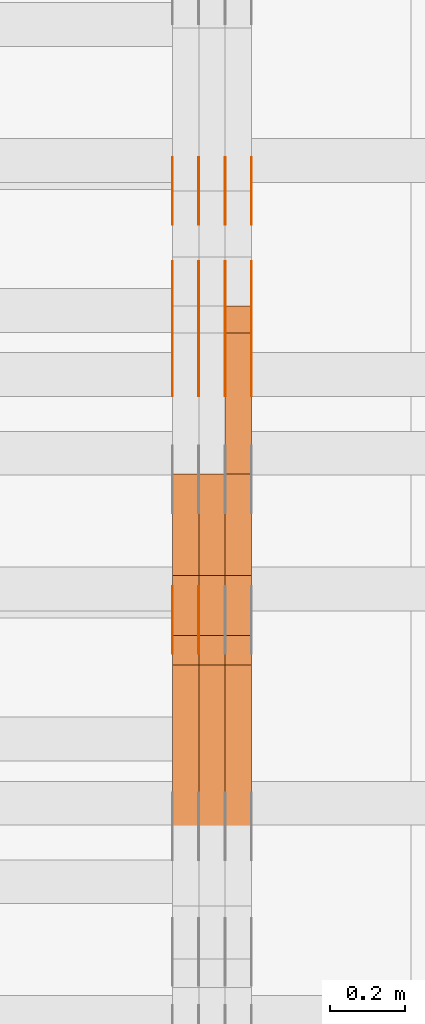
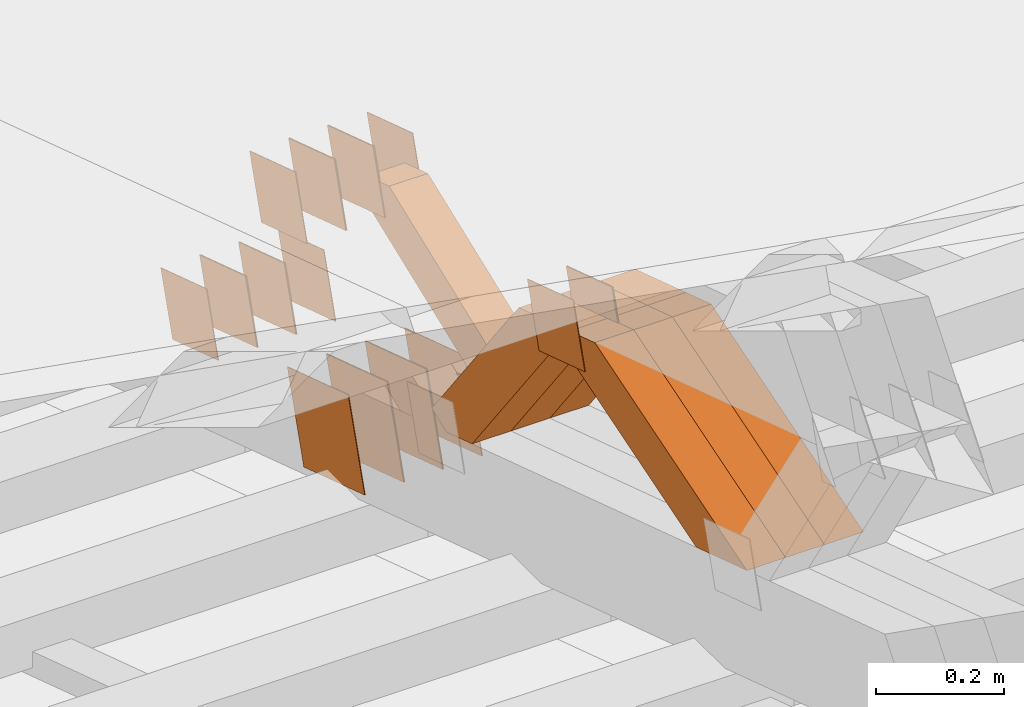
# One storey, part 176 of 385: 28 proxies.
"""IFC2X3 building model written with IfcOpenShell, lengths in millimetres."""

from ifc_helpers import new_model, entity, si_unit, converted_unit, derived_unit, direction, frame, origin, place, context, subcontext, project, spatial, polyline, outline, extrude, source, transform, mapped, material, type_object, type_shapes, element, save


model = new_model("IFC2X3")

# Units and contexts
model_context = context("Model", 3, precision=0.01, world=origin(), true_north=direction((6.12303176911189e-17, 1.0)))
body_context = subcontext(model_context, "Body", "Model", "MODEL_VIEW")
ifc_project = project(units=[si_unit("LENGTHUNIT", "METRE", prefix="MILLI"), si_unit("AREAUNIT", "SQUARE_METRE"), si_unit("VOLUMEUNIT", "CUBIC_METRE"), converted_unit("PLANEANGLEUNIT", "DEGREE", entity("IfcRatioMeasure", 0.0174532925199433), si_unit("PLANEANGLEUNIT", "RADIAN"), dimensions=[0, 0, 0, 0, 0, 0, 0]), si_unit("MASSUNIT", "GRAM", prefix="KILO"), derived_unit("MASSDENSITYUNIT", [(si_unit("MASSUNIT", "GRAM", prefix="KILO"), 1), (si_unit("LENGTHUNIT", "METRE"), -3)]), si_unit("TIMEUNIT", "SECOND"), si_unit("FREQUENCYUNIT", "HERTZ"), si_unit("THERMODYNAMICTEMPERATUREUNIT", "DEGREE_CELSIUS"), derived_unit("THERMALTRANSMITTANCEUNIT", [(si_unit("MASSUNIT", "GRAM", prefix="KILO"), 1), (si_unit("THERMODYNAMICTEMPERATUREUNIT", "KELVIN"), -1), (si_unit("TIMEUNIT", "SECOND"), -3)]), derived_unit("VOLUMETRICFLOWRATEUNIT", [(si_unit("LENGTHUNIT", "METRE"), 3), (si_unit("TIMEUNIT", "SECOND"), -1)]), si_unit("ELECTRICCURRENTUNIT", "AMPERE"), si_unit("ELECTRICVOLTAGEUNIT", "VOLT"), si_unit("POWERUNIT", "WATT"), si_unit("FORCEUNIT", "NEWTON", prefix="KILO"), si_unit("ILLUMINANCEUNIT", "LUX"), si_unit("LUMINOUSFLUXUNIT", "LUMEN"), si_unit("LUMINOUSINTENSITYUNIT", "CANDELA"), derived_unit("USERDEFINED", [(si_unit("MASSUNIT", "GRAM", prefix="KILO"), -1), (si_unit("LENGTHUNIT", "METRE"), -2), (si_unit("TIMEUNIT", "SECOND"), 3), (si_unit("LUMINOUSFLUXUNIT", "LUMEN"), 1)]), derived_unit("LINEARVELOCITYUNIT", [(si_unit("LENGTHUNIT", "METRE"), 1), (si_unit("TIMEUNIT", "SECOND"), -1)]), si_unit("PRESSUREUNIT", "PASCAL"), derived_unit("USERDEFINED", [(si_unit("LENGTHUNIT", "METRE"), -2), (si_unit("MASSUNIT", "GRAM", prefix="KILO"), 1), (si_unit("TIMEUNIT", "SECOND"), -2)])], contexts=[model_context])

# Site, building, storey
site_placement = place(None, origin())
site = spatial("IfcSite", under=ifc_project, at=site_placement, CompositionType="ELEMENT")
building_placement = place(site_placement, origin())
building = spatial("IfcBuilding", under=site, at=building_placement, CompositionType="ELEMENT")
storey_placement = place(building_placement, origin())
storey = spatial("IfcBuildingStorey", under=building, at=storey_placement, Name="Default", CompositionType="ELEMENT", Elevation=0.0)

# Proxies
ifc_material_1 = material(Name="IfcSurfaceStyle #68676")
building_element_proxy_type_1 = type_object("IfcBuildingElementProxyType", PredefinedType="NOTDEFINED", material=ifc_material_1)
shared_shape_1 = source(origin(), body_context, "Body", "SweptSolid", [
    extrude(outline(polyline([(-74.9998794200123, -59.999984515643), (74.9998565677174, -59.999984515643), (74.9998794200123, 59.999984515643), (-74.9998565677174, 59.999984515643), (-74.9998794200123, -59.999984515643)])), frame((75.0000769557496, 60.0000596852268, 0.0), z_axis=(0.0, 0.0, 1.0), x_axis=(-1.0, 0.0, 0.0)), (0.0, 0.0, 1.0), 1.3),
])
type_shapes(building_element_proxy_type_1, [shared_shape_1])
proxy_1_placement = place(building_placement, frame((3386.29999999999, 22649.3668870864, 1282.62115477841), z_axis=(-1.0, 0.0, 0.0), x_axis=(0.0, -0.951056516295124, 0.309016994375039)))
element("IfcBuildingElementProxy", 1, at=proxy_1_placement, inside=storey, type_object=building_element_proxy_type_1, material=ifc_material_1, context=body_context, shape_type="MappedRepresentation", body=[
    mapped(shared_shape_1, transform((0.0, 0.0, 0.0), scale=1.0)),
])
ifc_material_2 = material(Name="IfcSurfaceStyle #68619")
building_element_proxy_type_2 = type_object("IfcBuildingElementProxyType", PredefinedType="NOTDEFINED", material=ifc_material_2)
shared_shape_2 = source(origin(), body_context, "Body", "SweptSolid", [
    extrude(outline(polyline([(-74.9998794200123, -59.999984515643), (74.9998565677174, -59.999984515643), (74.9998794200123, 59.999984515643), (-74.9998565677174, 59.999984515643), (-74.9998794200123, -59.999984515643)])), frame((75.0000769557496, 60.0000596852268, 0.0), z_axis=(0.0, 0.0, 1.0), x_axis=(-1.0, 0.0, 0.0)), (0.0, 0.0, 1.0), 1.3),
])
type_shapes(building_element_proxy_type_2, [shared_shape_2])
proxy_2_placement = place(building_placement, frame((3315.0, 22649.3668870864, 1282.62115477841), z_axis=(-1.0, 0.0, 0.0), x_axis=(0.0, -0.951056516295124, 0.309016994375039)))
element("IfcBuildingElementProxy", 2, at=proxy_2_placement, inside=storey, type_object=building_element_proxy_type_2, material=ifc_material_2, context=body_context, shape_type="MappedRepresentation", body=[
    mapped(shared_shape_2, transform((0.0, 0.0, 0.0), scale=1.0)),
])
ifc_material_3 = material(Name="IfcSurfaceStyle #68562")
building_element_proxy_type_3 = type_object("IfcBuildingElementProxyType", PredefinedType="NOTDEFINED", material=ifc_material_3)
shared_shape_3 = source(origin(), body_context, "Body", "SweptSolid", [
    extrude(outline(polyline([(-74.9998794200123, -59.999984515643), (74.9998565677174, -59.999984515643), (74.9998794200123, 59.999984515643), (-74.9998565677174, 59.999984515643), (-74.9998794200123, -59.999984515643)])), frame((75.0000769557496, 60.0000596852268, 0.0), z_axis=(0.0, 0.0, 1.0), x_axis=(-1.0, 0.0, 0.0)), (0.0, 0.0, 1.0), 1.3),
])
type_shapes(building_element_proxy_type_3, [shared_shape_3])
proxy_3_placement = place(building_placement, frame((3316.29999999999, 22649.3668870864, 1282.62115477841), z_axis=(-1.0, 0.0, 0.0), x_axis=(0.0, -0.951056516295124, 0.309016994375039)))
element("IfcBuildingElementProxy", 3, at=proxy_3_placement, inside=storey, type_object=building_element_proxy_type_3, material=ifc_material_3, context=body_context, shape_type="MappedRepresentation", body=[
    mapped(shared_shape_3, transform((0.0, 0.0, 0.0), scale=1.0)),
])
ifc_material_4 = material(Name="IfcSurfaceStyle #68505")
building_element_proxy_type_4 = type_object("IfcBuildingElementProxyType", PredefinedType="NOTDEFINED", material=ifc_material_4)
shared_shape_4 = source(origin(), body_context, "Body", "SweptSolid", [
    extrude(outline(polyline([(-74.9998794200123, -59.999984515643), (74.9998565677174, -59.999984515643), (74.9998794200123, 59.999984515643), (-74.9998565677174, 59.999984515643), (-74.9998794200123, -59.999984515643)])), frame((75.0000769557496, 60.0000596852268, 0.0), z_axis=(0.0, 0.0, 1.0), x_axis=(-1.0, 0.0, 0.0)), (0.0, 0.0, 1.0), 1.29999999999999),
])
type_shapes(building_element_proxy_type_4, [shared_shape_4])
proxy_4_placement = place(building_placement, frame((3245.0, 22649.3668870864, 1282.62115477841), z_axis=(-1.0, 0.0, 0.0), x_axis=(0.0, -0.951056516295124, 0.309016994375039)))
element("IfcBuildingElementProxy", 4, at=proxy_4_placement, inside=storey, type_object=building_element_proxy_type_4, material=ifc_material_4, context=body_context, shape_type="MappedRepresentation", body=[
    mapped(shared_shape_4, transform((0.0, 0.0, 0.0), scale=1.0)),
])
ifc_material_5 = material(Name="IfcSurfaceStyle #68448")
building_element_proxy_type_5 = type_object("IfcBuildingElementProxyType", PredefinedType="NOTDEFINED", material=ifc_material_5)
shared_shape_5 = source(origin(), body_context, "Body", "SweptSolid", [
    extrude(outline(polyline([(-74.9998794200123, -59.999984515643), (74.9998565677174, -59.999984515643), (74.9998794200123, 59.999984515643), (-74.9998565677174, 59.999984515643), (-74.9998794200123, -59.999984515643)])), frame((75.0000769557496, 60.0000596852268, 0.0), z_axis=(0.0, 0.0, 1.0), x_axis=(-1.0, 0.0, 0.0)), (0.0, 0.0, 1.0), 1.29999999999999),
])
type_shapes(building_element_proxy_type_5, [shared_shape_5])
proxy_5_placement = place(building_placement, frame((3246.29999999999, 22649.3668870864, 1282.62115477841), z_axis=(-1.0, 0.0, 0.0), x_axis=(0.0, -0.951056516295124, 0.309016994375039)))
element("IfcBuildingElementProxy", 5, at=proxy_5_placement, inside=storey, type_object=building_element_proxy_type_5, material=ifc_material_5, context=body_context, shape_type="MappedRepresentation", body=[
    mapped(shared_shape_5, transform((0.0, 0.0, 0.0), scale=1.0)),
])
ifc_material_6 = material(Name="IfcSurfaceStyle #68391")
building_element_proxy_type_6 = type_object("IfcBuildingElementProxyType", PredefinedType="NOTDEFINED", material=ifc_material_6)
shared_shape_6 = source(origin(), body_context, "Body", "SweptSolid", [
    extrude(outline(polyline([(-74.9998794200123, -59.999984515643), (74.9998565677174, -59.999984515643), (74.9998794200123, 59.999984515643), (-74.9998565677174, 59.999984515643), (-74.9998794200123, -59.999984515643)])), frame((75.0000769557496, 60.0000596852268, 0.0), z_axis=(0.0, 0.0, 1.0), x_axis=(-1.0, 0.0, 0.0)), (0.0, 0.0, 1.0), 1.29999999999999),
])
type_shapes(building_element_proxy_type_6, [shared_shape_6])
proxy_6_placement = place(building_placement, frame((3175.0, 22649.3668870864, 1282.62115477841), z_axis=(-1.0, 0.0, 0.0), x_axis=(0.0, -0.951056516295124, 0.309016994375039)))
element("IfcBuildingElementProxy", 6, at=proxy_6_placement, inside=storey, type_object=building_element_proxy_type_6, material=ifc_material_6, context=body_context, shape_type="MappedRepresentation", body=[
    mapped(shared_shape_6, transform((0.0, 0.0, 0.0), scale=1.0)),
])
ifc_material_7 = material(Name="IfcSurfaceStyle #67992")
building_element_proxy_type_7 = type_object("IfcBuildingElementProxyType", PredefinedType="NOTDEFINED", material=ifc_material_7)
shared_shape_7 = source(origin(), body_context, "Body", "SweptSolid", [
    extrude(outline(polyline([(-99.9999579276585, -84.0000593595837), (100.000141865112, -84.0000593595837), (99.9999579276589, 84.0000593595837), (-100.000141865112, 84.0000593595837), (-99.9999579276585, -84.0000593595837)])), frame((100.000141865112, 84.0000593595837, 0.0), z_axis=(0.0, 0.0, 1.0), x_axis=(-1.0, 0.0, 0.0)), (0.0, 0.0, 1.0), 1.3),
])
type_shapes(building_element_proxy_type_7, [shared_shape_7])
proxy_7_placement = place(building_placement, frame((3386.29999999999, 22239.7296395088, 1287.96775368191), z_axis=(-1.0, 0.0, 0.0), x_axis=(0.0, -0.951056516295124, 0.309016994375039)))
element("IfcBuildingElementProxy", 7, at=proxy_7_placement, inside=storey, type_object=building_element_proxy_type_7, material=ifc_material_7, context=body_context, shape_type="MappedRepresentation", body=[
    mapped(shared_shape_7, transform((0.0, 0.0, 0.0), scale=1.0)),
])
ifc_material_8 = material(Name="IfcSurfaceStyle #67935")
building_element_proxy_type_8 = type_object("IfcBuildingElementProxyType", PredefinedType="NOTDEFINED", material=ifc_material_8)
shared_shape_8 = source(origin(), body_context, "Body", "SweptSolid", [
    extrude(outline(polyline([(-99.9999579276585, -84.0000593595837), (100.000141865112, -84.0000593595837), (99.9999579276589, 84.0000593595837), (-100.000141865112, 84.0000593595837), (-99.9999579276585, -84.0000593595837)])), frame((100.000141865112, 84.0000593595837, 0.0), z_axis=(0.0, 0.0, 1.0), x_axis=(-1.0, 0.0, 0.0)), (0.0, 0.0, 1.0), 1.3),
])
type_shapes(building_element_proxy_type_8, [shared_shape_8])
proxy_8_placement = place(building_placement, frame((3315.0, 22239.7296395088, 1287.96775368191), z_axis=(-1.0, 0.0, 0.0), x_axis=(0.0, -0.951056516295124, 0.309016994375039)))
element("IfcBuildingElementProxy", 8, at=proxy_8_placement, inside=storey, type_object=building_element_proxy_type_8, material=ifc_material_8, context=body_context, shape_type="MappedRepresentation", body=[
    mapped(shared_shape_8, transform((0.0, 0.0, 0.0), scale=1.0)),
])
ifc_material_9 = material(Name="IfcSurfaceStyle #67878")
building_element_proxy_type_9 = type_object("IfcBuildingElementProxyType", PredefinedType="NOTDEFINED", material=ifc_material_9)
shared_shape_9 = source(origin(), body_context, "Body", "SweptSolid", [
    extrude(outline(polyline([(-99.9999579276585, -84.0000593595837), (100.000141865112, -84.0000593595837), (99.9999579276589, 84.0000593595837), (-100.000141865112, 84.0000593595837), (-99.9999579276585, -84.0000593595837)])), frame((100.000141865112, 84.0000593595837, 0.0), z_axis=(0.0, 0.0, 1.0), x_axis=(-1.0, 0.0, 0.0)), (0.0, 0.0, 1.0), 1.3),
])
type_shapes(building_element_proxy_type_9, [shared_shape_9])
proxy_9_placement = place(building_placement, frame((3316.29999999999, 22239.7296395088, 1287.96775368191), z_axis=(-1.0, 0.0, 0.0), x_axis=(0.0, -0.951056516295124, 0.309016994375039)))
element("IfcBuildingElementProxy", 9, at=proxy_9_placement, inside=storey, type_object=building_element_proxy_type_9, material=ifc_material_9, context=body_context, shape_type="MappedRepresentation", body=[
    mapped(shared_shape_9, transform((0.0, 0.0, 0.0), scale=1.0)),
])
ifc_material_10 = material(Name="IfcSurfaceStyle #67821")
building_element_proxy_type_10 = type_object("IfcBuildingElementProxyType", PredefinedType="NOTDEFINED", material=ifc_material_10)
shared_shape_10 = source(origin(), body_context, "Body", "SweptSolid", [
    extrude(outline(polyline([(-99.9999579276585, -84.0000593595837), (100.000141865112, -84.0000593595837), (99.9999579276589, 84.0000593595837), (-100.000141865112, 84.0000593595837), (-99.9999579276585, -84.0000593595837)])), frame((100.000141865112, 84.0000593595837, 0.0), z_axis=(0.0, 0.0, 1.0), x_axis=(-1.0, 0.0, 0.0)), (0.0, 0.0, 1.0), 1.29999999999998),
])
type_shapes(building_element_proxy_type_10, [shared_shape_10])
proxy_10_placement = place(building_placement, frame((3245.0, 22239.7296395088, 1287.96775368191), z_axis=(-1.0, 0.0, 0.0), x_axis=(0.0, -0.951056516295124, 0.309016994375039)))
element("IfcBuildingElementProxy", 10, at=proxy_10_placement, inside=storey, type_object=building_element_proxy_type_10, material=ifc_material_10, context=body_context, shape_type="MappedRepresentation", body=[
    mapped(shared_shape_10, transform((0.0, 0.0, 0.0), scale=1.0)),
])
ifc_material_11 = material(Name="IfcSurfaceStyle #67764")
building_element_proxy_type_11 = type_object("IfcBuildingElementProxyType", PredefinedType="NOTDEFINED", material=ifc_material_11)
shared_shape_11 = source(origin(), body_context, "Body", "SweptSolid", [
    extrude(outline(polyline([(-99.9999579276585, -84.0000593595837), (100.000141865112, -84.0000593595837), (99.9999579276589, 84.0000593595837), (-100.000141865112, 84.0000593595837), (-99.9999579276585, -84.0000593595837)])), frame((100.000141865112, 84.0000593595837, 0.0), z_axis=(0.0, 0.0, 1.0), x_axis=(-1.0, 0.0, 0.0)), (0.0, 0.0, 1.0), 1.29999999999998),
])
type_shapes(building_element_proxy_type_11, [shared_shape_11])
proxy_11_placement = place(building_placement, frame((3246.29999999999, 22239.7296395088, 1287.96775368191), z_axis=(-1.0, 0.0, 0.0), x_axis=(0.0, -0.951056516295124, 0.309016994375039)))
element("IfcBuildingElementProxy", 11, at=proxy_11_placement, inside=storey, type_object=building_element_proxy_type_11, material=ifc_material_11, context=body_context, shape_type="MappedRepresentation", body=[
    mapped(shared_shape_11, transform((0.0, 0.0, 0.0), scale=1.0)),
])
ifc_material_12 = material(Name="IfcSurfaceStyle #67707")
building_element_proxy_type_12 = type_object("IfcBuildingElementProxyType", PredefinedType="NOTDEFINED", material=ifc_material_12)
shared_shape_12 = source(origin(), body_context, "Body", "SweptSolid", [
    extrude(outline(polyline([(-99.9999579276585, -84.0000593595837), (100.000141865112, -84.0000593595837), (99.9999579276589, 84.0000593595837), (-100.000141865112, 84.0000593595837), (-99.9999579276585, -84.0000593595837)])), frame((100.000141865112, 84.0000593595837, 0.0), z_axis=(0.0, 0.0, 1.0), x_axis=(-1.0, 0.0, 0.0)), (0.0, 0.0, 1.0), 1.29999999999999),
])
type_shapes(building_element_proxy_type_12, [shared_shape_12])
proxy_12_placement = place(building_placement, frame((3175.0, 22239.7296395088, 1287.96775368191), z_axis=(-1.0, 0.0, 0.0), x_axis=(0.0, -0.951056516295124, 0.309016994375039)))
element("IfcBuildingElementProxy", 12, at=proxy_12_placement, inside=storey, type_object=building_element_proxy_type_12, material=ifc_material_12, context=body_context, shape_type="MappedRepresentation", body=[
    mapped(shared_shape_12, transform((0.0, 0.0, 0.0), scale=1.0)),
])
ifc_material_13 = material(Name="IfcSurfaceStyle #59955")
building_element_proxy_type_13 = type_object("IfcBuildingElementProxyType", PredefinedType="NOTDEFINED", material=ifc_material_13)
shared_shape_13 = source(origin(), body_context, "Body", "SweptSolid", [
    extrude(outline(polyline([(-74.9998794200064, -59.9999845156358), (74.9998565677224, -59.9999845156358), (74.9998794200064, 59.9999845156358), (-74.9998565677224, 59.9999845156358), (-74.9998794200064, -59.9999845156358)])), frame((74.9999765995044, 60.0000596852337, 0.0), z_axis=(0.0, 0.0, 1.0), x_axis=(-1.0, 0.0, 0.0)), (0.0, 0.0, 1.0), 1.29999999999999),
])
type_shapes(building_element_proxy_type_13, [shared_shape_13])
proxy_13_placement = place(building_placement, frame((3245.0, 21505.9776314857, 1954.5332951652), z_axis=(-1.0, 0.0, 0.0), x_axis=(0.0, -0.951056516295154, 0.309016994374948)))
element("IfcBuildingElementProxy", 13, at=proxy_13_placement, inside=storey, type_object=building_element_proxy_type_13, material=ifc_material_13, context=body_context, shape_type="MappedRepresentation", body=[
    mapped(shared_shape_13, transform((0.0, 0.0, 0.0), scale=1.0)),
])
ifc_material_14 = material(Name="IfcSurfaceStyle #59898")
building_element_proxy_type_14 = type_object("IfcBuildingElementProxyType", PredefinedType="NOTDEFINED", material=ifc_material_14)
shared_shape_14 = source(origin(), body_context, "Body", "SweptSolid", [
    extrude(outline(polyline([(-74.9998794200064, -59.9999845156358), (74.9998565677224, -59.9999845156358), (74.9998794200064, 59.9999845156358), (-74.9998565677224, 59.9999845156358), (-74.9998794200064, -59.9999845156358)])), frame((74.9999765995044, 60.0000596852337, 0.0), z_axis=(0.0, 0.0, 1.0), x_axis=(-1.0, 0.0, 0.0)), (0.0, 0.0, 1.0), 1.29999999999999),
])
type_shapes(building_element_proxy_type_14, [shared_shape_14])
proxy_14_placement = place(building_placement, frame((3246.29999999999, 21505.9776314857, 1954.5332951652), z_axis=(-1.0, 0.0, 0.0), x_axis=(0.0, -0.951056516295154, 0.309016994374948)))
element("IfcBuildingElementProxy", 14, at=proxy_14_placement, inside=storey, type_object=building_element_proxy_type_14, material=ifc_material_14, context=body_context, shape_type="MappedRepresentation", body=[
    mapped(shared_shape_14, transform((0.0, 0.0, 0.0), scale=1.0)),
])
ifc_material_15 = material(Name="IfcSurfaceStyle #59841")
building_element_proxy_type_15 = type_object("IfcBuildingElementProxyType", PredefinedType="NOTDEFINED", material=ifc_material_15)
shared_shape_15 = source(origin(), body_context, "Body", "SweptSolid", [
    extrude(outline(polyline([(-74.9998794200064, -59.9999845156358), (74.9998565677224, -59.9999845156358), (74.9998794200064, 59.9999845156358), (-74.9998565677224, 59.9999845156358), (-74.9998794200064, -59.9999845156358)])), frame((74.9999765995044, 60.0000596852337, 0.0), z_axis=(0.0, 0.0, 1.0), x_axis=(-1.0, 0.0, 0.0)), (0.0, 0.0, 1.0), 1.29999999999999),
])
type_shapes(building_element_proxy_type_15, [shared_shape_15])
proxy_15_placement = place(building_placement, frame((3175.0, 21505.9776314857, 1954.5332951652), z_axis=(-1.0, 0.0, 0.0), x_axis=(0.0, -0.951056516295154, 0.309016994374948)))
element("IfcBuildingElementProxy", 15, at=proxy_15_placement, inside=storey, type_object=building_element_proxy_type_15, material=ifc_material_15, context=body_context, shape_type="MappedRepresentation", body=[
    mapped(shared_shape_15, transform((0.0, 0.0, 0.0), scale=1.0)),
])
ifc_material_16 = material(Name="IfcSurfaceStyle #59442")
building_element_proxy_type_16 = type_object("IfcBuildingElementProxyType", PredefinedType="NOTDEFINED", material=ifc_material_16)
shared_shape_16 = source(origin(), body_context, "Body", "SweptSolid", [
    extrude(outline(polyline([(-74.9998794200069, -59.9999845156358), (74.9998565677229, -59.9999845156358), (74.9998794200069, 59.9999845156358), (-74.9998565677229, 59.9999845156358), (-74.9998794200069, -59.9999845156358)])), frame((75.0000966453795, 60.0000596852335, 0.0), z_axis=(0.0, 0.0, 1.0), x_axis=(-1.0, 0.0, 0.0)), (0.0, 0.0, 1.0), 1.3),
])
type_shapes(building_element_proxy_type_16, [shared_shape_16])
proxy_16_placement = place(building_placement, frame((3386.29999999999, 22372.1881948749, 1673.08440552992), z_axis=(-1.0, 0.0, 0.0), x_axis=(0.0, -0.951056516295154, 0.309016994374948)))
element("IfcBuildingElementProxy", 16, at=proxy_16_placement, inside=storey, type_object=building_element_proxy_type_16, material=ifc_material_16, context=body_context, shape_type="MappedRepresentation", body=[
    mapped(shared_shape_16, transform((0.0, 0.0, 0.0), scale=1.0)),
])
ifc_material_17 = material(Name="IfcSurfaceStyle #59385")
building_element_proxy_type_17 = type_object("IfcBuildingElementProxyType", PredefinedType="NOTDEFINED", material=ifc_material_17)
shared_shape_17 = source(origin(), body_context, "Body", "SweptSolid", [
    extrude(outline(polyline([(-74.9998794200069, -59.9999845156358), (74.9998565677229, -59.9999845156358), (74.9998794200069, 59.9999845156358), (-74.9998565677229, 59.9999845156358), (-74.9998794200069, -59.9999845156358)])), frame((75.0000966453795, 60.0000596852335, 0.0), z_axis=(0.0, 0.0, 1.0), x_axis=(-1.0, 0.0, 0.0)), (0.0, 0.0, 1.0), 1.3),
])
type_shapes(building_element_proxy_type_17, [shared_shape_17])
proxy_17_placement = place(building_placement, frame((3315.0, 22372.1881948749, 1673.08440552992), z_axis=(-1.0, 0.0, 0.0), x_axis=(0.0, -0.951056516295154, 0.309016994374948)))
element("IfcBuildingElementProxy", 17, at=proxy_17_placement, inside=storey, type_object=building_element_proxy_type_17, material=ifc_material_17, context=body_context, shape_type="MappedRepresentation", body=[
    mapped(shared_shape_17, transform((0.0, 0.0, 0.0), scale=1.0)),
])
ifc_material_18 = material(Name="IfcSurfaceStyle #59328")
building_element_proxy_type_18 = type_object("IfcBuildingElementProxyType", PredefinedType="NOTDEFINED", material=ifc_material_18)
shared_shape_18 = source(origin(), body_context, "Body", "SweptSolid", [
    extrude(outline(polyline([(-74.9998794200069, -59.9999845156358), (74.9998565677229, -59.9999845156358), (74.9998794200069, 59.9999845156358), (-74.9998565677229, 59.9999845156358), (-74.9998794200069, -59.9999845156358)])), frame((75.0000966453795, 60.0000596852335, 0.0), z_axis=(0.0, 0.0, 1.0), x_axis=(-1.0, 0.0, 0.0)), (0.0, 0.0, 1.0), 1.3),
])
type_shapes(building_element_proxy_type_18, [shared_shape_18])
proxy_18_placement = place(building_placement, frame((3316.29999999999, 22372.1881948749, 1673.08440552992), z_axis=(-1.0, 0.0, 0.0), x_axis=(0.0, -0.951056516295154, 0.309016994374948)))
element("IfcBuildingElementProxy", 18, at=proxy_18_placement, inside=storey, type_object=building_element_proxy_type_18, material=ifc_material_18, context=body_context, shape_type="MappedRepresentation", body=[
    mapped(shared_shape_18, transform((0.0, 0.0, 0.0), scale=1.0)),
])
ifc_material_19 = material(Name="IfcSurfaceStyle #59271")
building_element_proxy_type_19 = type_object("IfcBuildingElementProxyType", PredefinedType="NOTDEFINED", material=ifc_material_19)
shared_shape_19 = source(origin(), body_context, "Body", "SweptSolid", [
    extrude(outline(polyline([(-74.9998794200069, -59.9999845156358), (74.9998565677229, -59.9999845156358), (74.9998794200069, 59.9999845156358), (-74.9998565677229, 59.9999845156358), (-74.9998794200069, -59.9999845156358)])), frame((75.0000966453795, 60.0000596852335, 0.0), z_axis=(0.0, 0.0, 1.0), x_axis=(-1.0, 0.0, 0.0)), (0.0, 0.0, 1.0), 1.29999999999999),
])
type_shapes(building_element_proxy_type_19, [shared_shape_19])
proxy_19_placement = place(building_placement, frame((3245.0, 22372.1881948749, 1673.08440552992), z_axis=(-1.0, 0.0, 0.0), x_axis=(0.0, -0.951056516295154, 0.309016994374948)))
element("IfcBuildingElementProxy", 19, at=proxy_19_placement, inside=storey, type_object=building_element_proxy_type_19, material=ifc_material_19, context=body_context, shape_type="MappedRepresentation", body=[
    mapped(shared_shape_19, transform((0.0, 0.0, 0.0), scale=1.0)),
])
ifc_material_20 = material(Name="IfcSurfaceStyle #59214")
building_element_proxy_type_20 = type_object("IfcBuildingElementProxyType", PredefinedType="NOTDEFINED", material=ifc_material_20)
shared_shape_20 = source(origin(), body_context, "Body", "SweptSolid", [
    extrude(outline(polyline([(-74.9998794200069, -59.9999845156358), (74.9998565677229, -59.9999845156358), (74.9998794200069, 59.9999845156358), (-74.9998565677229, 59.9999845156358), (-74.9998794200069, -59.9999845156358)])), frame((75.0000966453795, 60.0000596852335, 0.0), z_axis=(0.0, 0.0, 1.0), x_axis=(-1.0, 0.0, 0.0)), (0.0, 0.0, 1.0), 1.29999999999999),
])
type_shapes(building_element_proxy_type_20, [shared_shape_20])
proxy_20_placement = place(building_placement, frame((3246.29999999999, 22372.1881948749, 1673.08440552992), z_axis=(-1.0, 0.0, 0.0), x_axis=(0.0, -0.951056516295154, 0.309016994374948)))
element("IfcBuildingElementProxy", 20, at=proxy_20_placement, inside=storey, type_object=building_element_proxy_type_20, material=ifc_material_20, context=body_context, shape_type="MappedRepresentation", body=[
    mapped(shared_shape_20, transform((0.0, 0.0, 0.0), scale=1.0)),
])
ifc_material_21 = material(Name="IfcSurfaceStyle #59157")
building_element_proxy_type_21 = type_object("IfcBuildingElementProxyType", PredefinedType="NOTDEFINED", material=ifc_material_21)
shared_shape_21 = source(origin(), body_context, "Body", "SweptSolid", [
    extrude(outline(polyline([(-74.9998794200069, -59.9999845156358), (74.9998565677229, -59.9999845156358), (74.9998794200069, 59.9999845156358), (-74.9998565677229, 59.9999845156358), (-74.9998794200069, -59.9999845156358)])), frame((75.0000966453795, 60.0000596852335, 0.0), z_axis=(0.0, 0.0, 1.0), x_axis=(-1.0, 0.0, 0.0)), (0.0, 0.0, 1.0), 1.29999999999999),
])
type_shapes(building_element_proxy_type_21, [shared_shape_21])
proxy_21_placement = place(building_placement, frame((3175.0, 22372.1881948749, 1673.08440552992), z_axis=(-1.0, 0.0, 0.0), x_axis=(0.0, -0.951056516295154, 0.309016994374948)))
element("IfcBuildingElementProxy", 21, at=proxy_21_placement, inside=storey, type_object=building_element_proxy_type_21, material=ifc_material_21, context=body_context, shape_type="MappedRepresentation", body=[
    mapped(shared_shape_21, transform((0.0, 0.0, 0.0), scale=1.0)),
])
ifc_material_22 = material(Name="IfcSurfaceStyle #47886")
building_element_proxy_type_22 = type_object("IfcBuildingElementProxyType", Name="T1-W20 47884", PredefinedType="NOTDEFINED", material=ifc_material_22)
shared_shape_22 = source(origin(), body_context, "Body", "SweptSolid", [
    extrude(outline(polyline([(-355.264945969921, -47.5000317999193), (141.064821099313, -47.5000317999193), (208.541978467889, 8.19311626391928e-05), (225.96877763549, 47.499990834338), (-220.31063123277, 47.4999908343379), (-355.264945969921, -47.5000317999193)])), frame((225.968921063481, 47.5000683592689, 0.0), z_axis=(0.0, 0.0, 1.0), x_axis=(-1.0, 0.0, 0.0)), (0.0, 0.0, 1.0), 70.0),
])
type_shapes(building_element_proxy_type_22, [shared_shape_22])
proxy_22_placement = place(building_placement, frame((3385.0, 21443.7472302196, 2007.54830804072), z_axis=(-1.0, 0.0, 0.0), x_axis=(0.0, -0.95556995517236, -0.29476441571515)))
element("IfcBuildingElementProxy", 22, at=proxy_22_placement, inside=storey, type_object=building_element_proxy_type_22, material=ifc_material_22, Name="T1-W20", context=body_context, shape_type="MappedRepresentation", body=[
    mapped(shared_shape_22, transform((0.0, 0.0, 0.0), scale=1.0)),
])
ifc_material_23 = material(Name="IfcSurfaceStyle #47820")
building_element_proxy_type_23 = type_object("IfcBuildingElementProxyType", Name="T1-W20 47818", PredefinedType="NOTDEFINED", material=ifc_material_23)
shared_shape_23 = source(origin(), body_context, "Body", "SweptSolid", [
    extrude(outline(polyline([(-355.264945969921, -47.5000317999193), (141.064821099313, -47.5000317999193), (208.541978467889, 8.19311626391928e-05), (225.96877763549, 47.499990834338), (-220.31063123277, 47.4999908343379), (-355.264945969921, -47.5000317999193)])), frame((225.968921063481, 47.5000683592689, 0.0), z_axis=(0.0, 0.0, 1.0), x_axis=(-1.0, 0.0, 0.0)), (0.0, 0.0, 1.0), 70.0),
])
type_shapes(building_element_proxy_type_23, [shared_shape_23])
proxy_23_placement = place(building_placement, frame((3315.0, 21443.7472302196, 2007.54830804072), z_axis=(-1.0, 0.0, 0.0), x_axis=(0.0, -0.95556995517236, -0.29476441571515)))
element("IfcBuildingElementProxy", 23, at=proxy_23_placement, inside=storey, type_object=building_element_proxy_type_23, material=ifc_material_23, Name="T1-W20", context=body_context, shape_type="MappedRepresentation", body=[
    mapped(shared_shape_23, transform((0.0, 0.0, 0.0), scale=1.0)),
])
ifc_material_24 = material(Name="IfcSurfaceStyle #47754")
building_element_proxy_type_24 = type_object("IfcBuildingElementProxyType", Name="T1-W20 47752", PredefinedType="NOTDEFINED", material=ifc_material_24)
shared_shape_24 = source(origin(), body_context, "Body", "SweptSolid", [
    extrude(outline(polyline([(-355.264945969921, -47.5000317999193), (141.064821099313, -47.5000317999193), (208.541978467889, 8.19311626391928e-05), (225.96877763549, 47.499990834338), (-220.31063123277, 47.4999908343379), (-355.264945969921, -47.5000317999193)])), frame((225.968921063481, 47.5000683592689, 0.0), z_axis=(0.0, 0.0, 1.0), x_axis=(-1.0, 0.0, 0.0)), (0.0, 0.0, 1.0), 70.0),
])
type_shapes(building_element_proxy_type_24, [shared_shape_24])
proxy_24_placement = place(building_placement, frame((3245.0, 21443.7472302196, 2007.54830804072), z_axis=(-1.0, 0.0, 0.0), x_axis=(0.0, -0.95556995517236, -0.29476441571515)))
element("IfcBuildingElementProxy", 24, at=proxy_24_placement, inside=storey, type_object=building_element_proxy_type_24, material=ifc_material_24, Name="T1-W20", context=body_context, shape_type="MappedRepresentation", body=[
    mapped(shared_shape_24, transform((0.0, 0.0, 0.0), scale=1.0)),
])
ifc_material_25 = material(Name="IfcSurfaceStyle #47490")
building_element_proxy_type_25 = type_object("IfcBuildingElementProxyType", Name="T1-W18 47488", PredefinedType="NOTDEFINED", material=ifc_material_25)
shared_shape_25 = source(origin(), body_context, "Body", "SweptSolid", [
    extrude(outline(polyline([(-221.504996322134, -47.4999929258616), (225.406467948779, -47.4999929258616), (211.663832468686, -0.000107703153482008), (143.08905281687, 47.5000467774384), (-358.6543569122, 47.5000467774384), (-221.504996322134, -47.4999929258616)])), frame((225.406576158364, 47.5000467774384, 0.0), z_axis=(0.0, 0.0, 1.0), x_axis=(-1.0, 0.0, 0.0)), (0.0, 0.0, 1.0), 70.0),
])
type_shapes(building_element_proxy_type_25, [shared_shape_25])
proxy_25_placement = place(building_placement, frame((3385.0, 21766.9513837803, 1583.13813361817), z_axis=(-1.0, 0.0, 0.0), x_axis=(0.0, -0.605858491298265, 0.795572428206126)))
element("IfcBuildingElementProxy", 25, at=proxy_25_placement, inside=storey, type_object=building_element_proxy_type_25, material=ifc_material_25, Name="T1-W18", context=body_context, shape_type="MappedRepresentation", body=[
    mapped(shared_shape_25, transform((0.0, 0.0, 0.0), scale=1.0)),
])
ifc_material_26 = material(Name="IfcSurfaceStyle #47424")
building_element_proxy_type_26 = type_object("IfcBuildingElementProxyType", Name="T1-W18 47422", PredefinedType="NOTDEFINED", material=ifc_material_26)
shared_shape_26 = source(origin(), body_context, "Body", "SweptSolid", [
    extrude(outline(polyline([(-221.504996322134, -47.4999929258616), (225.406467948779, -47.4999929258616), (211.663832468686, -0.000107703153482008), (143.08905281687, 47.5000467774384), (-358.6543569122, 47.5000467774384), (-221.504996322134, -47.4999929258616)])), frame((225.406576158364, 47.5000467774384, 0.0), z_axis=(0.0, 0.0, 1.0), x_axis=(-1.0, 0.0, 0.0)), (0.0, 0.0, 1.0), 70.0),
])
type_shapes(building_element_proxy_type_26, [shared_shape_26])
proxy_26_placement = place(building_placement, frame((3315.0, 21766.9513837803, 1583.13813361817), z_axis=(-1.0, 0.0, 0.0), x_axis=(0.0, -0.605858491298265, 0.795572428206126)))
element("IfcBuildingElementProxy", 26, at=proxy_26_placement, inside=storey, type_object=building_element_proxy_type_26, material=ifc_material_26, Name="T1-W18", context=body_context, shape_type="MappedRepresentation", body=[
    mapped(shared_shape_26, transform((0.0, 0.0, 0.0), scale=1.0)),
])
ifc_material_27 = material(Name="IfcSurfaceStyle #47358")
building_element_proxy_type_27 = type_object("IfcBuildingElementProxyType", Name="T1-W18 47356", PredefinedType="NOTDEFINED", material=ifc_material_27)
shared_shape_27 = source(origin(), body_context, "Body", "SweptSolid", [
    extrude(outline(polyline([(-221.504996322134, -47.4999929258616), (225.406467948779, -47.4999929258616), (211.663832468686, -0.000107703153482008), (143.08905281687, 47.5000467774384), (-358.6543569122, 47.5000467774384), (-221.504996322134, -47.4999929258616)])), frame((225.406576158364, 47.5000467774384, 0.0), z_axis=(0.0, 0.0, 1.0), x_axis=(-1.0, 0.0, 0.0)), (0.0, 0.0, 1.0), 70.0),
])
type_shapes(building_element_proxy_type_27, [shared_shape_27])
proxy_27_placement = place(building_placement, frame((3245.0, 21766.9513837803, 1583.13813361817), z_axis=(-1.0, 0.0, 0.0), x_axis=(0.0, -0.605858491298265, 0.795572428206126)))
element("IfcBuildingElementProxy", 27, at=proxy_27_placement, inside=storey, type_object=building_element_proxy_type_27, material=ifc_material_27, Name="T1-W18", context=body_context, shape_type="MappedRepresentation", body=[
    mapped(shared_shape_27, transform((0.0, 0.0, 0.0), scale=1.0)),
])
ifc_material_28 = material(Name="IfcSurfaceStyle #47094")
building_element_proxy_type_28 = type_object("IfcBuildingElementProxyType", Name="T1-W30 47092", PredefinedType="NOTDEFINED", material=ifc_material_28)
shared_shape_28 = source(origin(), body_context, "Body", "SweptSolid", [
    extrude(outline(polyline([(-319.322304176575, -47.5000259045904), (133.154090927094, -47.5000259045904), (191.489196707701, 6.99403755251016e-06), (197.330697834052, 47.5000224075717), (-202.651681292271, 47.5000224075717), (-319.322304176575, -47.5000259045904)])), frame((197.330834478517, 47.5000608592405, 0.0), z_axis=(0.0, 0.0, 1.0), x_axis=(-1.0, 0.0, 0.0)), (0.0, 0.0, 1.0), 70.0),
])
type_shapes(building_element_proxy_type_28, [shared_shape_28])
proxy_28_placement = place(building_placement, frame((3385.0, 22312.5352975627, 1720.70362673362), z_axis=(-1.0, 0.0, 0.0), x_axis=(0.0, -0.932610696879359, -0.360884036868072)))
element("IfcBuildingElementProxy", 28, at=proxy_28_placement, inside=storey, type_object=building_element_proxy_type_28, material=ifc_material_28, Name="T1-W30", context=body_context, shape_type="MappedRepresentation", body=[
    mapped(shared_shape_28, transform((0.0, 0.0, 0.0), scale=1.0)),
])

save(model, "model.ifc")
